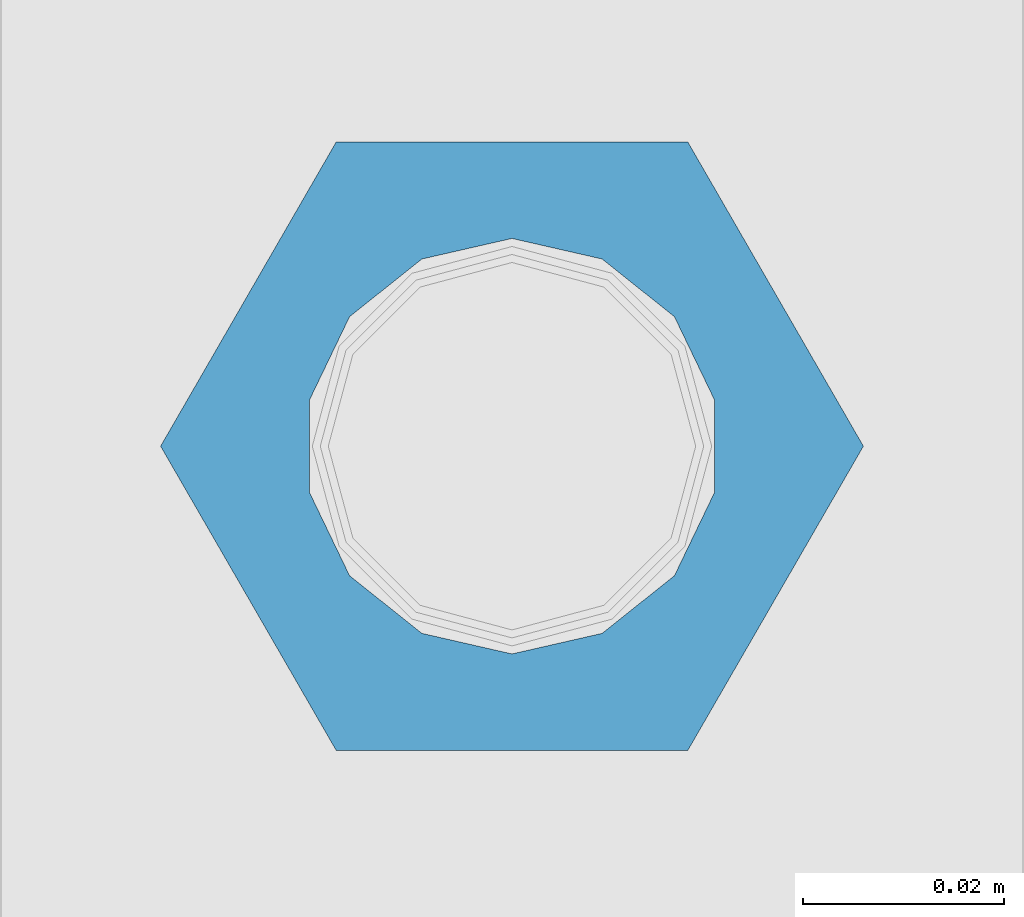
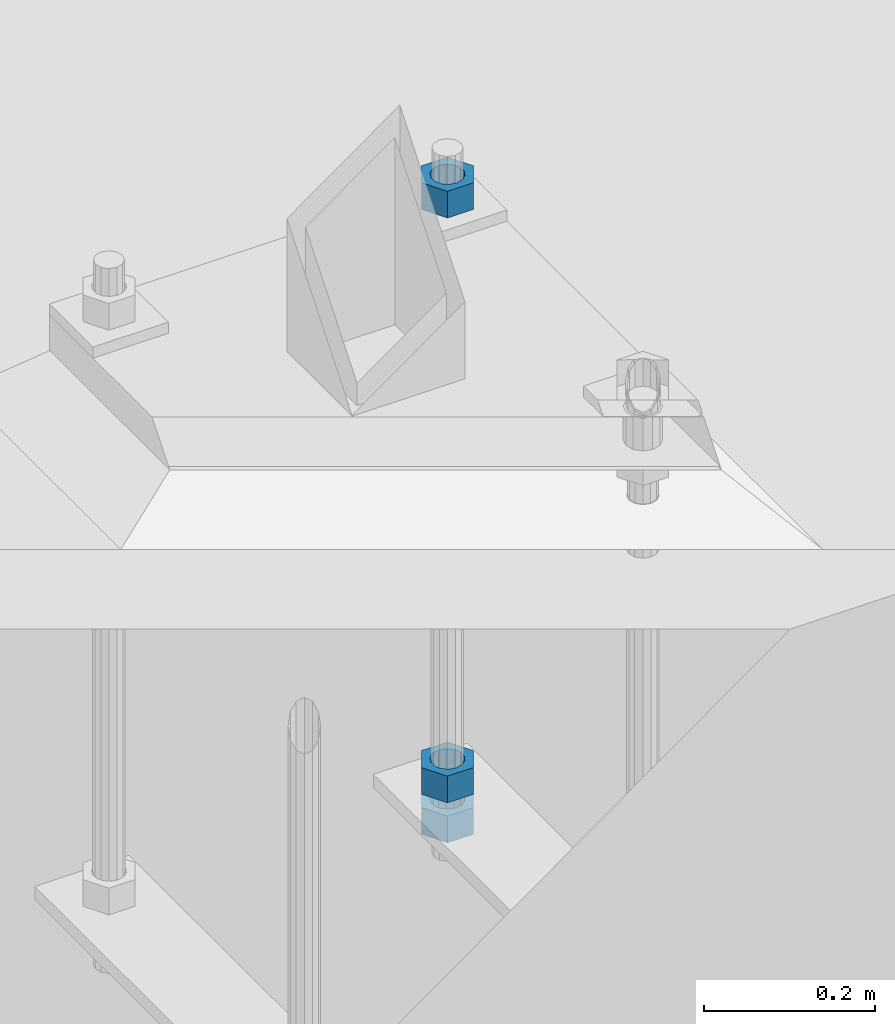
# One storey, part 961 of 1179: 3 beams, 1 element without a shape of its own.
"""IFC2X3 building model written with IfcOpenShell, lengths in millimetres."""

from ifc_helpers import new_model, si_unit, frame, origin_with_axes, place, context, subcontext, project, spatial, faceted_brep, material, type_object, element, aggregate, save


model = new_model("IFC2X3")

# Units and contexts
model_context = context("Model", 3, precision=1e-05, world=origin_with_axes())
body_context = subcontext(model_context, "Body", "Model", "MODEL_VIEW")
ifc_project = project(units=[si_unit("LENGTHUNIT", "METRE", prefix="MILLI"), si_unit("AREAUNIT", "SQUARE_METRE"), si_unit("VOLUMEUNIT", "CUBIC_METRE"), si_unit("MASSUNIT", "GRAM", prefix="KILO"), si_unit("TIMEUNIT", "SECOND"), si_unit("PLANEANGLEUNIT", "RADIAN"), si_unit("SOLIDANGLEUNIT", "STERADIAN"), si_unit("THERMODYNAMICTEMPERATUREUNIT", "DEGREE_CELSIUS"), si_unit("LUMINOUSINTENSITYUNIT", "LUMEN")], contexts=[model_context])

# Site, building, storey
site_placement = place(None, origin_with_axes())
site = spatial("IfcSite", under=ifc_project, at=site_placement, CompositionType="ELEMENT")
building_placement = place(site_placement, origin_with_axes())
building = spatial("IfcBuilding", under=site, at=building_placement, Name="Undefined", CompositionType="ELEMENT")
storey_placement = place(building_placement, origin_with_axes())
storey = spatial("IfcBuildingStorey", under=building, at=storey_placement, Name="Undefined", CompositionType="ELEMENT", Elevation=0.0)

# Assembly, beams
assembly_placement = place(storey_placement, origin_with_axes())
assembly = element("IfcElementAssembly", 1, at=assembly_placement, inside=storey, Name="TEMPLATE", AssemblyPlace="NOTDEFINED", PredefinedType="RIGID_FRAME")
ifc_material = material(Name="STEEL/A36")
beam_type = type_object("IfcBeamType", Name="1-1/2_HEAVY_HEX_NUT", PredefinedType="NOTDEFINED")
beam_1_placement = place(assembly_placement, frame((27990.8, 4876.79999389648, -1009.65), z_axis=(0.0, -1.0, 0.0), x_axis=(0.0, 0.0, -1.0)))
beam_1 = element("IfcBeam", 2, at=beam_1_placement, type_object=beam_type, material=ifc_material, Name="NUT", ObjectType="1-1/2_HEAVY_HEX_NUT", context=body_context, shape_type="Brep", body=[
    faceted_brep([(0.0, -34.9199981689453, 0.0), (0.0, -17.4599990844727, -30.25), (38.0999999999985, -17.4599990844727, -30.25), (38.0999999999985, -34.9199981689453, 0.0), (0.0, 17.4599990844727, -30.25), (38.0999999999985, 17.4599990844727, -30.25), (0.0, 34.9199981689453, 0.0), (38.0999999999985, 34.9199981689453, 0.0), (0.0, 17.4599990844727, 30.25), (38.0999999999985, 17.4599990844727, 30.25), (0.0, -17.4599990844727, 30.25), (38.0999999999985, -17.4599990844727, 30.25), (0.0, 0.0, 20.6399993896484), (0.0, 8.95536011056538, 18.5959968835978), (38.0999999999985, 8.95536011056538, 18.5959968835978), (38.0999999999985, 0.0, 20.6399993896484), (0.0, 16.1370013209489, 12.8688291298158), (38.0999999999985, 16.1370013209489, 12.8688291298158), (0.0, 20.1225115123852, 4.59283194104228), (38.0999999999985, 20.1225115123852, 4.59283194104228), (0.0, 20.1225115123852, -4.59283194104228), (38.0999999999985, 20.1225115123852, -4.59283194104228), (0.0, 16.1370013209489, -12.8688291298167), (38.0999999999985, 16.1370013209489, -12.8688291298167), (0.0, 8.95536011056538, -18.5959968835978), (38.0999999999985, 8.95536011056538, -18.5959968835978), (0.0, 0.0, -20.6399993896484), (38.0999999999985, 0.0, -20.6399993896484), (0.0, -8.95536011056538, -18.5959968835978), (38.0999999999985, -8.95536011056538, -18.5959968835978), (0.0, -16.1370013209489, -12.8688291298158), (38.0999999999985, -16.1370013209489, -12.8688291298158), (0.0, -20.1225115123852, -4.59283194104228), (38.0999999999985, -20.1225115123852, -4.59283194104228), (0.0, -20.1225115123852, 4.59283194104228), (38.0999999999985, -20.1225115123852, 4.59283194104228), (0.0, -16.1370013209489, 12.8688291298167), (38.0999999999985, -16.1370013209489, 12.8688291298167), (0.0, -8.95536011056538, 18.5959968835978), (38.0999999999985, -8.95536011056538, 18.5959968835978)], [[[0, 1, 2, 3]], [[1, 4, 5, 2]], [[4, 6, 7, 5]], [[6, 8, 9, 7]], [[8, 10, 11, 9]], [[10, 0, 3, 11]], [[12, 13, 14, 15]], [[13, 16, 17, 14]], [[16, 18, 19, 17]], [[18, 20, 21, 19]], [[20, 22, 23, 21]], [[22, 24, 25, 23]], [[24, 26, 27, 25]], [[26, 28, 29, 27]], [[28, 30, 31, 29]], [[30, 32, 33, 31]], [[32, 34, 35, 33]], [[34, 36, 37, 35]], [[36, 38, 39, 37]], [[38, 12, 15, 39]], [[5, 7, 9, 11, 3, 2], [17, 19, 21, 23, 25, 27, 29, 31, 33, 35, 37, 39, 15, 14]], [[10, 8, 6, 4, 1, 0], [38, 36, 34, 32, 30, 28, 26, 24, 22, 20, 18, 16, 13, 12]]]),
])
beam_2_placement = place(assembly_placement, frame((27990.8, 4876.79999389648, -1066.8), z_axis=(0.0, -1.0, 0.0), x_axis=(0.0, 0.0, -1.0)))
beam_2 = element("IfcBeam", 3, at=beam_2_placement, type_object=beam_type, material=ifc_material, Name="NUT", ObjectType="1-1/2_HEAVY_HEX_NUT", context=body_context, shape_type="Brep", body=[
    faceted_brep([(0.0, -34.9199981689453, 0.0), (0.0, -17.4599990844727, -30.25), (38.0999999999985, -17.4599990844727, -30.25), (38.0999999999985, -34.9199981689453, 0.0), (0.0, 17.4599990844727, -30.25), (38.0999999999985, 17.4599990844727, -30.25), (0.0, 34.9199981689453, 0.0), (38.0999999999985, 34.9199981689453, 0.0), (0.0, 17.4599990844727, 30.25), (38.0999999999985, 17.4599990844727, 30.25), (0.0, -17.4599990844727, 30.25), (38.0999999999985, -17.4599990844727, 30.25), (0.0, 0.0, 20.6399993896484), (0.0, 8.95536011056538, 18.5959968835978), (38.0999999999985, 8.95536011056538, 18.5959968835978), (38.0999999999985, 0.0, 20.6399993896484), (0.0, 16.1370013209489, 12.8688291298158), (38.0999999999985, 16.1370013209489, 12.8688291298158), (0.0, 20.1225115123852, 4.59283194104228), (38.0999999999985, 20.1225115123852, 4.59283194104228), (0.0, 20.1225115123852, -4.59283194104228), (38.0999999999985, 20.1225115123852, -4.59283194104228), (0.0, 16.1370013209489, -12.8688291298167), (38.0999999999985, 16.1370013209489, -12.8688291298167), (0.0, 8.95536011056538, -18.5959968835978), (38.0999999999985, 8.95536011056538, -18.5959968835978), (0.0, 0.0, -20.6399993896484), (38.0999999999985, 0.0, -20.6399993896484), (0.0, -8.95536011056538, -18.5959968835978), (38.0999999999985, -8.95536011056538, -18.5959968835978), (0.0, -16.1370013209489, -12.8688291298158), (38.0999999999985, -16.1370013209489, -12.8688291298158), (0.0, -20.1225115123852, -4.59283194104228), (38.0999999999985, -20.1225115123852, -4.59283194104228), (0.0, -20.1225115123852, 4.59283194104228), (38.0999999999985, -20.1225115123852, 4.59283194104228), (0.0, -16.1370013209489, 12.8688291298167), (38.0999999999985, -16.1370013209489, 12.8688291298167), (0.0, -8.95536011056538, 18.5959968835978), (38.0999999999985, -8.95536011056538, 18.5959968835978)], [[[0, 1, 2, 3]], [[1, 4, 5, 2]], [[4, 6, 7, 5]], [[6, 8, 9, 7]], [[8, 10, 11, 9]], [[10, 0, 3, 11]], [[12, 13, 14, 15]], [[13, 16, 17, 14]], [[16, 18, 19, 17]], [[18, 20, 21, 19]], [[20, 22, 23, 21]], [[22, 24, 25, 23]], [[24, 26, 27, 25]], [[26, 28, 29, 27]], [[28, 30, 31, 29]], [[30, 32, 33, 31]], [[32, 34, 35, 33]], [[34, 36, 37, 35]], [[36, 38, 39, 37]], [[38, 12, 15, 39]], [[5, 7, 9, 11, 3, 2], [17, 19, 21, 23, 25, 27, 29, 31, 33, 35, 37, 39, 15, 14]], [[10, 8, 6, 4, 1, 0], [38, 36, 34, 32, 30, 28, 26, 24, 22, 20, 18, 16, 13, 12]]]),
])
beam_3_placement = place(assembly_placement, frame((27990.8, 4876.79999389648, -174.625), z_axis=(0.0, 1.0, 0.0), x_axis=(0.0, 0.0, -1.0)))
beam_3 = element("IfcBeam", 4, at=beam_3_placement, type_object=beam_type, material=ifc_material, Name="NUT", ObjectType="1-1/2_HEAVY_HEX_NUT", context=body_context, shape_type="Brep", body=[
    faceted_brep([(0.0, -34.9199981689453, 0.0), (0.0, -17.4599990844727, -30.25), (38.0999999999985, -17.4599990844727, -30.25), (38.0999999999985, -34.9199981689453, 0.0), (0.0, 17.4599990844727, -30.25), (38.0999999999985, 17.4599990844727, -30.25), (0.0, 34.9199981689453, 0.0), (38.0999999999985, 34.9199981689453, 0.0), (0.0, 17.4599990844727, 30.25), (38.0999999999985, 17.4599990844727, 30.25), (0.0, -17.4599990844727, 30.25), (38.0999999999985, -17.4599990844727, 30.25), (0.0, 0.0, 20.6399993896484), (0.0, 8.95536011056538, 18.5959968835978), (38.0999999999985, 8.95536011056538, 18.5959968835978), (38.0999999999985, 0.0, 20.6399993896484), (0.0, 16.1370013209489, 12.8688291298158), (38.0999999999985, 16.1370013209489, 12.8688291298158), (0.0, 20.1225115123852, 4.59283194104228), (38.0999999999985, 20.1225115123852, 4.59283194104228), (0.0, 20.1225115123852, -4.59283194104228), (38.0999999999985, 20.1225115123852, -4.59283194104228), (0.0, 16.1370013209489, -12.8688291298167), (38.0999999999985, 16.1370013209489, -12.8688291298167), (0.0, 8.95536011056538, -18.5959968835978), (38.0999999999985, 8.95536011056538, -18.5959968835978), (0.0, 0.0, -20.6399993896484), (38.0999999999985, 0.0, -20.6399993896484), (0.0, -8.95536011056538, -18.5959968835978), (38.0999999999985, -8.95536011056538, -18.5959968835978), (0.0, -16.1370013209489, -12.8688291298158), (38.0999999999985, -16.1370013209489, -12.8688291298158), (0.0, -20.1225115123852, -4.59283194104228), (38.0999999999985, -20.1225115123852, -4.59283194104228), (0.0, -20.1225115123852, 4.59283194104228), (38.0999999999985, -20.1225115123852, 4.59283194104228), (0.0, -16.1370013209489, 12.8688291298167), (38.0999999999985, -16.1370013209489, 12.8688291298167), (0.0, -8.95536011056538, 18.5959968835978), (38.0999999999985, -8.95536011056538, 18.5959968835978)], [[[0, 1, 2, 3]], [[1, 4, 5, 2]], [[4, 6, 7, 5]], [[6, 8, 9, 7]], [[8, 10, 11, 9]], [[10, 0, 3, 11]], [[12, 13, 14, 15]], [[13, 16, 17, 14]], [[16, 18, 19, 17]], [[18, 20, 21, 19]], [[20, 22, 23, 21]], [[22, 24, 25, 23]], [[24, 26, 27, 25]], [[26, 28, 29, 27]], [[28, 30, 31, 29]], [[30, 32, 33, 31]], [[32, 34, 35, 33]], [[34, 36, 37, 35]], [[36, 38, 39, 37]], [[38, 12, 15, 39]], [[5, 7, 9, 11, 3, 2], [17, 19, 21, 23, 25, 27, 29, 31, 33, 35, 37, 39, 15, 14]], [[10, 8, 6, 4, 1, 0], [38, 36, 34, 32, 30, 28, 26, 24, 22, 20, 18, 16, 13, 12]]]),
])
aggregate(assembly, [beam_1, beam_2, beam_3])

save(model, "model.ifc")
